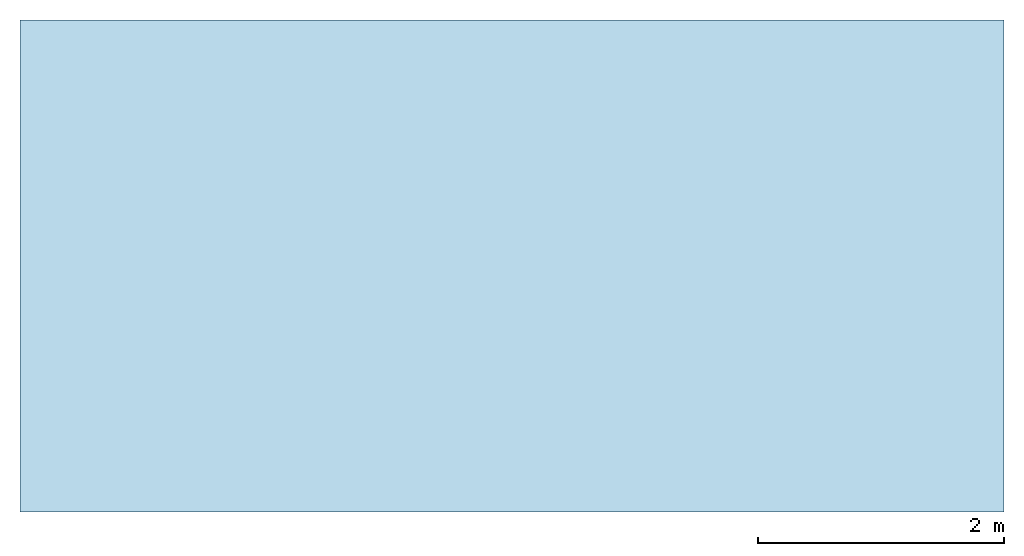
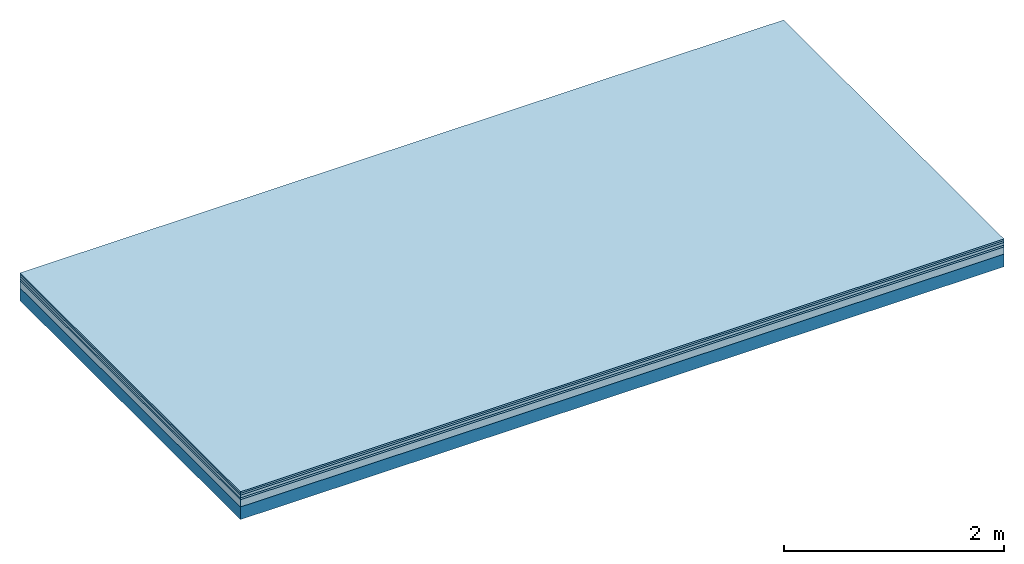
# One storey: 5 plates, 1 member, 1 element without a shape of its own.
"""IFC4 building model written with IfcOpenShell, lengths in metres."""

from ifc_helpers import new_model, si_unit, derived_unit, direction, frame, frame_2d, origin, origin_with_axes, place, context, project, spatial, rectangle, extrude, material, layer, layer_set, type_object, element, aggregate, save


model = new_model("IFC4")

# Units and contexts
plan_context = context("Plan", 3, precision=1e-05, world=origin(), true_north=direction((0.0, 1.0)))
model_context = context("Model", 3, precision=1e-05, world=origin(), true_north=direction((0.0, 1.0)))
ifc_project = project(units=[si_unit("LENGTHUNIT", "METRE"), derived_unit("SOUNDPRESSUREUNIT", [(si_unit("PRESSUREUNIT", "PASCAL", prefix="MICRO"), 0)]), si_unit("ENERGYUNIT", "JOULE", prefix="MEGA"), si_unit("MASSUNIT", "GRAM", prefix="KILO"), derived_unit("THERMALTRANSMITTANCEUNIT", [(si_unit("POWERUNIT", "WATT"), 1), (si_unit("AREAUNIT", "SQUARE_METRE"), -1), (si_unit("THERMODYNAMICTEMPERATUREUNIT", "KELVIN"), -1)]), derived_unit("AREADENSITYUNIT", [(si_unit("MASSUNIT", "GRAM", prefix="KILO"), 1), (si_unit("AREAUNIT", "SQUARE_METRE"), -1)]), derived_unit("USERDEFINED", [(si_unit("ENERGYUNIT", "JOULE", prefix="MEGA"), 1), (si_unit("AREAUNIT", "SQUARE_METRE"), -1)])], contexts=[plan_context, model_context])

# Site, building, storey
site = spatial("IfcSite", under=ifc_project)
building_placement = place(None, origin())
building = spatial("IfcBuilding", under=site, at=building_placement)
storey_placement = place(building_placement, origin())
storey = spatial("IfcBuildingStorey", under=building, at=storey_placement)

# Slab, member, plates
ifc_material_1 = material(Name="Floor heating system Therm38 longitudinal", Category="03.007")
ifc_layer_1 = layer(ifc_material_1, 0.018, Name="Flooring")
ifc_material_2 = material()
ifc_layer_2 = layer(ifc_material_2, 0.02, Name="layer")
ifc_material_3 = material(Name="Phone Star TRI", Category="03.013")
ifc_layer_3 = layer(ifc_material_3, 0.03, Name="On-material")
ifc_material_4 = material(Name="EP3")
ifc_layer_4 = layer(ifc_material_4, 0.02, Name="Impact sound insulation")
ifc_material_5 = material(Category="03.011")
ifc_layer_5 = layer(ifc_material_5, 0.08, Name="on Supporting structure")
ifc_material_6 = material(Name="no composite action")
ifc_layer_6 = layer(ifc_material_6, 0.0, Name="Bond")
ifc_layer_7 = layer(None, 0.14, Name="Supporting structure")
ifc_layer_set = layer_set([ifc_layer_1, ifc_layer_2, ifc_layer_3, ifc_layer_4, ifc_layer_5, ifc_layer_6, ifc_layer_7])
slab_type = type_object("IfcSlabType", Name="A2505", PredefinedType="NOTDEFINED", material=ifc_layer_set)
slab_placement = place(None, frame((0.0, 0.0, 0.0), z_axis=(0.0, 0.0, -1.0), x_axis=(1.0, 0.0, 0.0)))
slab = element("IfcSlab", 1, at=slab_placement, inside=storey, type_object=slab_type, material=ifc_layer_set, Name="Slab #1")
ifc_material_7 = material()
member_placement = place(slab_placement, origin())
member = element("IfcMember", 2, at=member_placement, material=ifc_material_7, Name="Supporting structure", context=plan_context, shape_type="SweptSolid", body=[
    extrude(rectangle(XDim=1.0, YDim=0.14, at=frame_2d((0.5, 0.07), x_axis=(1.0, 0.0))), frame((0.0, 4.0, 0.168), z_axis=(0.0, -1.0, 0.0), x_axis=(1.0, 0.0, 0.0)), (0.0, 0.0, 1.0), 4.0),
    extrude(rectangle(XDim=1.0, YDim=0.14, at=frame_2d((0.5, 0.07), x_axis=(1.0, 0.0))), frame((1.0, 4.0, 0.168), z_axis=(0.0, -1.0, 0.0), x_axis=(1.0, 0.0, 0.0)), (0.0, 0.0, 1.0), 4.0),
    extrude(rectangle(XDim=1.0, YDim=0.14, at=frame_2d((0.5, 0.07), x_axis=(1.0, 0.0))), frame((2.0, 4.0, 0.168), z_axis=(0.0, -1.0, 0.0), x_axis=(1.0, 0.0, 0.0)), (0.0, 0.0, 1.0), 4.0),
    extrude(rectangle(XDim=1.0, YDim=0.14, at=frame_2d((0.5, 0.07), x_axis=(1.0, 0.0))), frame((3.0, 4.0, 0.168), z_axis=(0.0, -1.0, 0.0), x_axis=(1.0, 0.0, 0.0)), (0.0, 0.0, 1.0), 4.0),
    extrude(rectangle(XDim=1.0, YDim=0.14, at=frame_2d((0.5, 0.07), x_axis=(1.0, 0.0))), frame((4.0, 4.0, 0.168), z_axis=(0.0, -1.0, 0.0), x_axis=(1.0, 0.0, 0.0)), (0.0, 0.0, 1.0), 4.0),
    extrude(rectangle(XDim=1.0, YDim=0.14, at=frame_2d((0.5, 0.07), x_axis=(1.0, 0.0))), frame((5.0, 4.0, 0.168), z_axis=(0.0, -1.0, 0.0), x_axis=(1.0, 0.0, 0.0)), (0.0, 0.0, 1.0), 4.0),
    extrude(rectangle(XDim=1.0, YDim=0.14, at=frame_2d((0.5, 0.07), x_axis=(1.0, 0.0))), frame((6.0, 4.0, 0.168), z_axis=(0.0, -1.0, 0.0), x_axis=(1.0, 0.0, 0.0)), (0.0, 0.0, 1.0), 4.0),
    extrude(rectangle(XDim=1.0, YDim=0.14, at=frame_2d((0.5, 0.07), x_axis=(1.0, 0.0))), frame((7.0, 4.0, 0.168), z_axis=(0.0, -1.0, 0.0), x_axis=(1.0, 0.0, 0.0)), (0.0, 0.0, 1.0), 4.0),
])
plate_1_placement = place(slab_placement, origin())
plate_1 = element("IfcPlate", 3, at=plate_1_placement, material=ifc_material_1, Name="Flooring", context=plan_context, shape_type="SweptSolid", body=[
    extrude(rectangle(XDim=8.0, YDim=4.0, at=frame_2d((4.0, 2.0), x_axis=(1.0, 0.0))), origin_with_axes(), (0.0, 0.0, 1.0), 0.018),
])
plate_2_placement = place(slab_placement, origin())
plate_2 = element("IfcPlate", 4, at=plate_2_placement, material=ifc_material_2, Name="layer", context=plan_context, shape_type="SweptSolid", body=[
    extrude(rectangle(XDim=8.0, YDim=4.0, at=frame_2d((4.0, 2.0), x_axis=(1.0, 0.0))), frame((0.0, 0.0, 0.018), z_axis=(0.0, 0.0, 1.0), x_axis=(1.0, 0.0, 0.0)), (0.0, 0.0, 1.0), 0.02),
])
plate_3_placement = place(slab_placement, origin())
plate_3 = element("IfcPlate", 5, at=plate_3_placement, material=ifc_material_3, Name="On-material", context=plan_context, shape_type="SweptSolid", body=[
    extrude(rectangle(XDim=8.0, YDim=4.0, at=frame_2d((4.0, 2.0), x_axis=(1.0, 0.0))), frame((0.0, 0.0, 0.038), z_axis=(0.0, 0.0, 1.0), x_axis=(1.0, 0.0, 0.0)), (0.0, 0.0, 1.0), 0.03),
])
plate_4_placement = place(slab_placement, origin())
plate_4 = element("IfcPlate", 6, at=plate_4_placement, material=ifc_material_4, Name="Impact sound insulation", context=plan_context, shape_type="SweptSolid", body=[
    extrude(rectangle(XDim=8.0, YDim=4.0, at=frame_2d((4.0, 2.0), x_axis=(1.0, 0.0))), frame((0.0, 0.0, 0.068), z_axis=(0.0, 0.0, 1.0), x_axis=(1.0, 0.0, 0.0)), (0.0, 0.0, 1.0), 0.02),
])
plate_5_placement = place(slab_placement, origin())
plate_5 = element("IfcPlate", 7, at=plate_5_placement, material=ifc_material_5, Name="on Supporting structure", context=plan_context, shape_type="SweptSolid", body=[
    extrude(rectangle(XDim=8.0, YDim=4.0, at=frame_2d((4.0, 2.0), x_axis=(1.0, 0.0))), frame((0.0, 0.0, 0.088), z_axis=(0.0, 0.0, 1.0), x_axis=(1.0, 0.0, 0.0)), (0.0, 0.0, 1.0), 0.08),
])
aggregate(slab, [plate_1, plate_2, plate_3, plate_4, plate_5, member])

save(model, "model.ifc")
